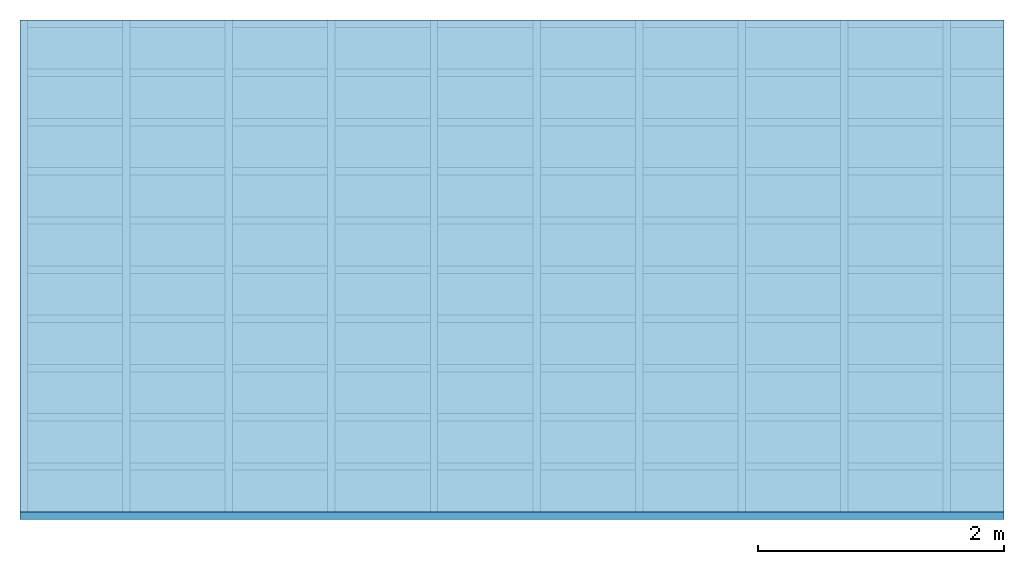
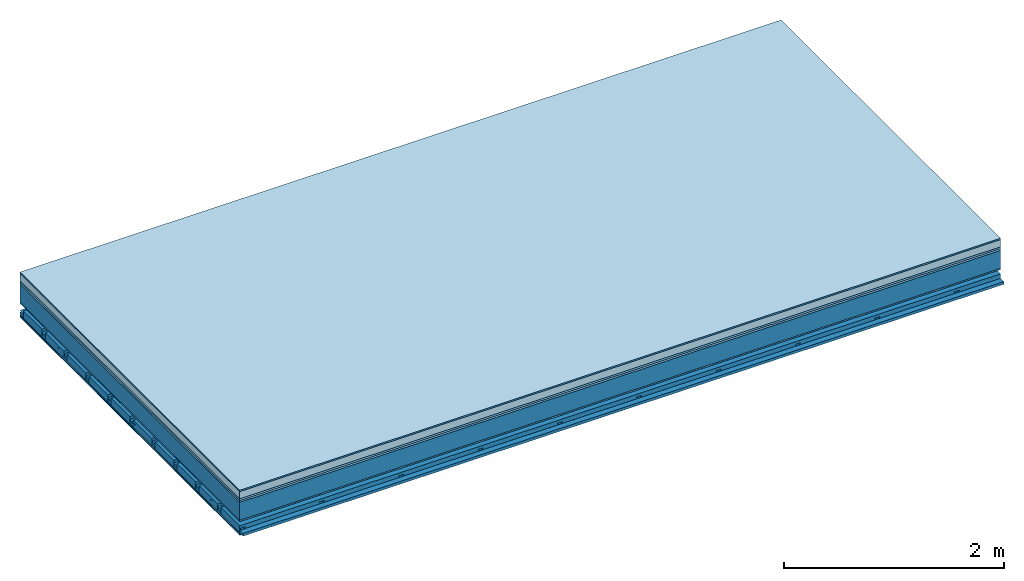
# One storey: 8 plates, 4 members, 1 element without a shape of its own.
"""IFC4 building model written with IfcOpenShell, lengths in metres."""

from ifc_helpers import new_model, si_unit, derived_unit, direction, frame, frame_2d, origin, origin_with_axes, place, context, project, spatial, polyline, rectangle, outline, extrude, material, layer, layer_set, type_object, element, aggregate, save


model = new_model("IFC4")

# Units and contexts
plan_context = context("Plan", 3, precision=1e-05, world=origin(), true_north=direction((0.0, 1.0)))
model_context = context("Model", 3, precision=1e-05, world=origin(), true_north=direction((0.0, 1.0)))
ifc_project = project(units=[si_unit("LENGTHUNIT", "METRE"), derived_unit("SOUNDPRESSUREUNIT", [(si_unit("PRESSUREUNIT", "PASCAL", prefix="MICRO"), 0)]), si_unit("ENERGYUNIT", "JOULE", prefix="MEGA"), si_unit("MASSUNIT", "GRAM", prefix="KILO"), derived_unit("THERMALTRANSMITTANCEUNIT", [(si_unit("POWERUNIT", "WATT"), 1), (si_unit("AREAUNIT", "SQUARE_METRE"), -1), (si_unit("THERMODYNAMICTEMPERATUREUNIT", "KELVIN"), -1)]), derived_unit("AREADENSITYUNIT", [(si_unit("MASSUNIT", "GRAM", prefix="KILO"), 1), (si_unit("AREAUNIT", "SQUARE_METRE"), -1)]), derived_unit("USERDEFINED", [(si_unit("ENERGYUNIT", "JOULE", prefix="MEGA"), 1), (si_unit("AREAUNIT", "SQUARE_METRE"), -1)])], contexts=[plan_context, model_context])

# Site, building, storey
site = spatial("IfcSite", under=ifc_project)
building_placement = place(None, origin())
building = spatial("IfcBuilding", under=site, at=building_placement)
storey_placement = place(building_placement, origin())
storey = spatial("IfcBuildingStorey", under=building, at=storey_placement)

# Slab, members, plates
ifc_material_1 = material(Category="11.013")
ifc_layer_1 = layer(ifc_material_1, 0.015, Name="Flooring")
ifc_material_2 = material(Name="Cement screed", Category="04.006")
ifc_layer_2 = layer(ifc_material_2, 0.08, Name="On-material")
ifc_material_3 = material(Name="Wood fiber generic product", Category="10.009")
ifc_layer_3 = layer(ifc_material_3, 0.02, Name="Impact sound insulation")
ifc_material_4 = material(Category="10.004")
ifc_layer_4 = layer(ifc_material_4, 0.02, Name="Additional insulation")
ifc_material_5 = material(Name="no composite action")
ifc_layer_5 = layer(ifc_material_5, 0.0, Name="Bond")
ifc_layer_6 = layer(None, 0.2, Name="Supporting structure")
ifc_material_6 = material(Name="of the art")
ifc_layer_7 = layer(ifc_material_6, 0.0, Name="Bond")
ifc_material_7 = material(Category="03.007")
ifc_layer_8 = layer(ifc_material_7, 0.015, Name="Lower layer 1")
ifc_layer_9 = layer(None, 0.095, Name="Coupling")
ifc_layer_10 = layer(None, 0.03, Name="Battens / profiles")
ifc_material_8 = material(Name="Plasterboard type A", Category="03.008")
ifc_layer_11 = layer(ifc_material_8, 0.0125, Name="Ceiling covering 1st layer")
ifc_layer_12 = layer(ifc_material_8, 0.0125, Name="Ceiling covering layer 2")
ifc_material_9 = material(Category="04.001")
ifc_layer_13 = layer(ifc_material_9, 0.003, Name="Surface / treatment")
ifc_layer_set = layer_set([ifc_layer_1, ifc_layer_2, ifc_layer_3, ifc_layer_4, ifc_layer_5, ifc_layer_6, ifc_layer_7, ifc_layer_8, ifc_layer_9, ifc_layer_10, ifc_layer_11, ifc_layer_12, ifc_layer_13])
slab_type = type_object("IfcSlabType", Name="A2163", PredefinedType="NOTDEFINED", material=ifc_layer_set)
slab_placement = place(None, frame((0.0, 0.0, 0.0), z_axis=(0.0, 0.0, -1.0), x_axis=(1.0, 0.0, 0.0)))
slab = element("IfcSlab", 1, at=slab_placement, inside=storey, type_object=slab_type, material=ifc_layer_set, Name="Slab #1")
ifc_material_10 = material(Name="Solid timber panel")
member_1_placement = place(slab_placement, origin())
member_1 = element("IfcMember", 2, at=member_1_placement, material=ifc_material_10, Name="Supporting structure", context=plan_context, shape_type="SweptSolid", body=[
    extrude(rectangle(XDim=1.0, YDim=0.2, at=frame_2d((0.5, 0.1), x_axis=(1.0, 0.0))), frame((0.0, 4.0, 0.135), z_axis=(0.0, -1.0, 0.0), x_axis=(1.0, 0.0, 0.0)), (0.0, 0.0, 1.0), 4.0),
    extrude(rectangle(XDim=1.0, YDim=0.2, at=frame_2d((0.5, 0.1), x_axis=(1.0, 0.0))), frame((1.0, 4.0, 0.135), z_axis=(0.0, -1.0, 0.0), x_axis=(1.0, 0.0, 0.0)), (0.0, 0.0, 1.0), 4.0),
    extrude(rectangle(XDim=1.0, YDim=0.2, at=frame_2d((0.5, 0.1), x_axis=(1.0, 0.0))), frame((2.0, 4.0, 0.135), z_axis=(0.0, -1.0, 0.0), x_axis=(1.0, 0.0, 0.0)), (0.0, 0.0, 1.0), 4.0),
    extrude(rectangle(XDim=1.0, YDim=0.2, at=frame_2d((0.5, 0.1), x_axis=(1.0, 0.0))), frame((3.0, 4.0, 0.135), z_axis=(0.0, -1.0, 0.0), x_axis=(1.0, 0.0, 0.0)), (0.0, 0.0, 1.0), 4.0),
    extrude(rectangle(XDim=1.0, YDim=0.2, at=frame_2d((0.5, 0.1), x_axis=(1.0, 0.0))), frame((4.0, 4.0, 0.135), z_axis=(0.0, -1.0, 0.0), x_axis=(1.0, 0.0, 0.0)), (0.0, 0.0, 1.0), 4.0),
    extrude(rectangle(XDim=1.0, YDim=0.2, at=frame_2d((0.5, 0.1), x_axis=(1.0, 0.0))), frame((5.0, 4.0, 0.135), z_axis=(0.0, -1.0, 0.0), x_axis=(1.0, 0.0, 0.0)), (0.0, 0.0, 1.0), 4.0),
    extrude(rectangle(XDim=1.0, YDim=0.2, at=frame_2d((0.5, 0.1), x_axis=(1.0, 0.0))), frame((6.0, 4.0, 0.135), z_axis=(0.0, -1.0, 0.0), x_axis=(1.0, 0.0, 0.0)), (0.0, 0.0, 1.0), 4.0),
    extrude(rectangle(XDim=1.0, YDim=0.2, at=frame_2d((0.5, 0.1), x_axis=(1.0, 0.0))), frame((7.0, 4.0, 0.135), z_axis=(0.0, -1.0, 0.0), x_axis=(1.0, 0.0, 0.0)), (0.0, 0.0, 1.0), 4.0),
])
ifc_material_11 = material()
member_2_placement = place(slab_placement, origin())
member_2 = element("IfcMember", 3, at=member_2_placement, material=ifc_material_11, Name="Coupling", context=plan_context, shape_type="SweptSolid", body=[
    extrude(outline(polyline([(0.0, 0.0), (0.06, 0.0), (0.04, 0.02), (0.02, 0.02), (0.0, 0.0)])), frame((0.0, 4.0, 0.425), z_axis=(0.0, -1.0, 0.0), x_axis=(1.0, 0.0, 0.0)), (0.0, 0.0, 1.0), 4.0),
    extrude(outline(polyline([(0.0, 0.0), (0.06, 0.0), (0.04, 0.02), (0.02, 0.02), (0.0, 0.0)])), frame((0.834, 4.0, 0.425), z_axis=(0.0, -1.0, 0.0), x_axis=(1.0, 0.0, 0.0)), (0.0, 0.0, 1.0), 4.0),
    extrude(outline(polyline([(0.0, 0.0), (0.06, 0.0), (0.04, 0.02), (0.02, 0.02), (0.0, 0.0)])), frame((1.668, 4.0, 0.425), z_axis=(0.0, -1.0, 0.0), x_axis=(1.0, 0.0, 0.0)), (0.0, 0.0, 1.0), 4.0),
    extrude(outline(polyline([(0.0, 0.0), (0.06, 0.0), (0.04, 0.02), (0.02, 0.02), (0.0, 0.0)])), frame((2.502, 4.0, 0.425), z_axis=(0.0, -1.0, 0.0), x_axis=(1.0, 0.0, 0.0)), (0.0, 0.0, 1.0), 4.0),
    extrude(outline(polyline([(0.0, 0.0), (0.06, 0.0), (0.04, 0.02), (0.02, 0.02), (0.0, 0.0)])), frame((3.336, 4.0, 0.425), z_axis=(0.0, -1.0, 0.0), x_axis=(1.0, 0.0, 0.0)), (0.0, 0.0, 1.0), 4.0),
    extrude(outline(polyline([(0.0, 0.0), (0.06, 0.0), (0.04, 0.02), (0.02, 0.02), (0.0, 0.0)])), frame((4.17, 4.0, 0.425), z_axis=(0.0, -1.0, 0.0), x_axis=(1.0, 0.0, 0.0)), (0.0, 0.0, 1.0), 4.0),
    extrude(outline(polyline([(0.0, 0.0), (0.06, 0.0), (0.04, 0.02), (0.02, 0.02), (0.0, 0.0)])), frame((5.004, 4.0, 0.425), z_axis=(0.0, -1.0, 0.0), x_axis=(1.0, 0.0, 0.0)), (0.0, 0.0, 1.0), 4.0),
    extrude(outline(polyline([(0.0, 0.0), (0.06, 0.0), (0.04, 0.02), (0.02, 0.02), (0.0, 0.0)])), frame((5.838, 4.0, 0.425), z_axis=(0.0, -1.0, 0.0), x_axis=(1.0, 0.0, 0.0)), (0.0, 0.0, 1.0), 4.0),
    extrude(outline(polyline([(0.0, 0.0), (0.06, 0.0), (0.04, 0.02), (0.02, 0.02), (0.0, 0.0)])), frame((6.672, 4.0, 0.425), z_axis=(0.0, -1.0, 0.0), x_axis=(1.0, 0.0, 0.0)), (0.0, 0.0, 1.0), 4.0),
    extrude(outline(polyline([(0.0, 0.0), (0.06, 0.0), (0.04, 0.02), (0.02, 0.02), (0.0, 0.0)])), frame((7.506, 4.0, 0.425), z_axis=(0.0, -1.0, 0.0), x_axis=(1.0, 0.0, 0.0)), (0.0, 0.0, 1.0), 4.0),
])
member_3_placement = place(slab_placement, origin())
member_3 = element("IfcMember", 4, at=member_3_placement, material=ifc_material_11, Name="Battens / profiles", context=plan_context, shape_type="SweptSolid", body=[
    extrude(rectangle(XDim=0.06, YDim=0.03, at=frame_2d((0.03, 0.015), x_axis=(1.0, 0.0))), frame((0.0, 0.0, 0.445), z_axis=(1.0, 0.0, 0.0), x_axis=(0.0, 1.0, 0.0)), (0.0, 0.0, 1.0), 8.0),
    extrude(rectangle(XDim=0.06, YDim=0.03, at=frame_2d((0.03, 0.015), x_axis=(1.0, 0.0))), frame((0.0, 0.4, 0.445), z_axis=(1.0, 0.0, 0.0), x_axis=(0.0, 1.0, 0.0)), (0.0, 0.0, 1.0), 8.0),
    extrude(rectangle(XDim=0.06, YDim=0.03, at=frame_2d((0.03, 0.015), x_axis=(1.0, 0.0))), frame((0.0, 0.8, 0.445), z_axis=(1.0, 0.0, 0.0), x_axis=(0.0, 1.0, 0.0)), (0.0, 0.0, 1.0), 8.0),
    extrude(rectangle(XDim=0.06, YDim=0.03, at=frame_2d((0.03, 0.015), x_axis=(1.0, 0.0))), frame((0.0, 1.2, 0.445), z_axis=(1.0, 0.0, 0.0), x_axis=(0.0, 1.0, 0.0)), (0.0, 0.0, 1.0), 8.0),
    extrude(rectangle(XDim=0.06, YDim=0.03, at=frame_2d((0.03, 0.015), x_axis=(1.0, 0.0))), frame((0.0, 1.6, 0.445), z_axis=(1.0, 0.0, 0.0), x_axis=(0.0, 1.0, 0.0)), (0.0, 0.0, 1.0), 8.0),
    extrude(rectangle(XDim=0.06, YDim=0.03, at=frame_2d((0.03, 0.015), x_axis=(1.0, 0.0))), frame((0.0, 2.0, 0.445), z_axis=(1.0, 0.0, 0.0), x_axis=(0.0, 1.0, 0.0)), (0.0, 0.0, 1.0), 8.0),
    extrude(rectangle(XDim=0.06, YDim=0.03, at=frame_2d((0.03, 0.015), x_axis=(1.0, 0.0))), frame((0.0, 2.4, 0.445), z_axis=(1.0, 0.0, 0.0), x_axis=(0.0, 1.0, 0.0)), (0.0, 0.0, 1.0), 8.0),
    extrude(rectangle(XDim=0.06, YDim=0.03, at=frame_2d((0.03, 0.015), x_axis=(1.0, 0.0))), frame((0.0, 2.8, 0.445), z_axis=(1.0, 0.0, 0.0), x_axis=(0.0, 1.0, 0.0)), (0.0, 0.0, 1.0), 8.0),
    extrude(rectangle(XDim=0.06, YDim=0.03, at=frame_2d((0.03, 0.015), x_axis=(1.0, 0.0))), frame((0.0, 3.2, 0.445), z_axis=(1.0, 0.0, 0.0), x_axis=(0.0, 1.0, 0.0)), (0.0, 0.0, 1.0), 8.0),
    extrude(rectangle(XDim=0.06, YDim=0.03, at=frame_2d((0.03, 0.015), x_axis=(1.0, 0.0))), frame((0.0, 3.6, 0.445), z_axis=(1.0, 0.0, 0.0), x_axis=(0.0, 1.0, 0.0)), (0.0, 0.0, 1.0), 8.0),
    extrude(rectangle(XDim=0.06, YDim=0.03, at=frame_2d((0.03, 0.015), x_axis=(1.0, 0.0))), frame((0.0, 4.0, 0.445), z_axis=(1.0, 0.0, 0.0), x_axis=(0.0, 1.0, 0.0)), (0.0, 0.0, 1.0), 8.0),
])
ifc_material_12 = material()
member_4_placement = place(slab_placement, origin())
member_4 = element("IfcMember", 5, at=member_4_placement, material=ifc_material_12, Name="Cavity", context=plan_context, shape_type="SweptSolid", body=[
    extrude(rectangle(XDim=0.34, YDim=0.08, at=frame_2d((0.17, 0.04), x_axis=(1.0, 0.0))), frame((0.0, 0.06, 0.395), z_axis=(1.0, 0.0, 0.0), x_axis=(0.0, 1.0, 0.0)), (0.0, 0.0, 1.0), 8.0),
    extrude(rectangle(XDim=0.34, YDim=0.08, at=frame_2d((0.17, 0.04), x_axis=(1.0, 0.0))), frame((0.0, 0.46, 0.395), z_axis=(1.0, 0.0, 0.0), x_axis=(0.0, 1.0, 0.0)), (0.0, 0.0, 1.0), 8.0),
    extrude(rectangle(XDim=0.34, YDim=0.08, at=frame_2d((0.17, 0.04), x_axis=(1.0, 0.0))), frame((0.0, 0.86, 0.395), z_axis=(1.0, 0.0, 0.0), x_axis=(0.0, 1.0, 0.0)), (0.0, 0.0, 1.0), 8.0),
    extrude(rectangle(XDim=0.34, YDim=0.08, at=frame_2d((0.17, 0.04), x_axis=(1.0, 0.0))), frame((0.0, 1.26, 0.395), z_axis=(1.0, 0.0, 0.0), x_axis=(0.0, 1.0, 0.0)), (0.0, 0.0, 1.0), 8.0),
    extrude(rectangle(XDim=0.34, YDim=0.08, at=frame_2d((0.17, 0.04), x_axis=(1.0, 0.0))), frame((0.0, 1.66, 0.395), z_axis=(1.0, 0.0, 0.0), x_axis=(0.0, 1.0, 0.0)), (0.0, 0.0, 1.0), 8.0),
    extrude(rectangle(XDim=0.34, YDim=0.08, at=frame_2d((0.17, 0.04), x_axis=(1.0, 0.0))), frame((0.0, 2.06, 0.395), z_axis=(1.0, 0.0, 0.0), x_axis=(0.0, 1.0, 0.0)), (0.0, 0.0, 1.0), 8.0),
    extrude(rectangle(XDim=0.34, YDim=0.08, at=frame_2d((0.17, 0.04), x_axis=(1.0, 0.0))), frame((0.0, 2.46, 0.395), z_axis=(1.0, 0.0, 0.0), x_axis=(0.0, 1.0, 0.0)), (0.0, 0.0, 1.0), 8.0),
    extrude(rectangle(XDim=0.34, YDim=0.08, at=frame_2d((0.17, 0.04), x_axis=(1.0, 0.0))), frame((0.0, 2.86, 0.395), z_axis=(1.0, 0.0, 0.0), x_axis=(0.0, 1.0, 0.0)), (0.0, 0.0, 1.0), 8.0),
    extrude(rectangle(XDim=0.34, YDim=0.08, at=frame_2d((0.17, 0.04), x_axis=(1.0, 0.0))), frame((0.0, 3.26, 0.395), z_axis=(1.0, 0.0, 0.0), x_axis=(0.0, 1.0, 0.0)), (0.0, 0.0, 1.0), 8.0),
    extrude(rectangle(XDim=0.34, YDim=0.08, at=frame_2d((0.17, 0.04), x_axis=(1.0, 0.0))), frame((0.0, 3.66, 0.395), z_axis=(1.0, 0.0, 0.0), x_axis=(0.0, 1.0, 0.0)), (0.0, 0.0, 1.0), 8.0),
])
plate_1_placement = place(slab_placement, origin())
plate_1 = element("IfcPlate", 6, at=plate_1_placement, material=ifc_material_1, Name="Flooring", context=plan_context, shape_type="SweptSolid", body=[
    extrude(rectangle(XDim=8.0, YDim=4.0, at=frame_2d((4.0, 2.0), x_axis=(1.0, 0.0))), origin_with_axes(), (0.0, 0.0, 1.0), 0.015),
])
plate_2_placement = place(slab_placement, origin())
plate_2 = element("IfcPlate", 7, at=plate_2_placement, material=ifc_material_2, Name="On-material", context=plan_context, shape_type="SweptSolid", body=[
    extrude(rectangle(XDim=8.0, YDim=4.0, at=frame_2d((4.0, 2.0), x_axis=(1.0, 0.0))), frame((0.0, 0.0, 0.015), z_axis=(0.0, 0.0, 1.0), x_axis=(1.0, 0.0, 0.0)), (0.0, 0.0, 1.0), 0.08),
])
plate_3_placement = place(slab_placement, origin())
plate_3 = element("IfcPlate", 8, at=plate_3_placement, material=ifc_material_3, Name="Impact sound insulation", context=plan_context, shape_type="SweptSolid", body=[
    extrude(rectangle(XDim=8.0, YDim=4.0, at=frame_2d((4.0, 2.0), x_axis=(1.0, 0.0))), frame((0.0, 0.0, 0.095), z_axis=(0.0, 0.0, 1.0), x_axis=(1.0, 0.0, 0.0)), (0.0, 0.0, 1.0), 0.02),
])
plate_4_placement = place(slab_placement, origin())
plate_4 = element("IfcPlate", 9, at=plate_4_placement, material=ifc_material_4, Name="Additional insulation", context=plan_context, shape_type="SweptSolid", body=[
    extrude(rectangle(XDim=8.0, YDim=4.0, at=frame_2d((4.0, 2.0), x_axis=(1.0, 0.0))), frame((0.0, 0.0, 0.115), z_axis=(0.0, 0.0, 1.0), x_axis=(1.0, 0.0, 0.0)), (0.0, 0.0, 1.0), 0.02),
])
plate_5_placement = place(slab_placement, origin())
plate_5 = element("IfcPlate", 10, at=plate_5_placement, material=ifc_material_7, Name="Lower layer 1", context=plan_context, shape_type="SweptSolid", body=[
    extrude(rectangle(XDim=8.0, YDim=4.0, at=frame_2d((4.0, 2.0), x_axis=(1.0, 0.0))), frame((0.0, 0.0, 0.335), z_axis=(0.0, 0.0, 1.0), x_axis=(1.0, 0.0, 0.0)), (0.0, 0.0, 1.0), 0.015),
])
plate_6_placement = place(slab_placement, origin())
plate_6 = element("IfcPlate", 11, at=plate_6_placement, material=ifc_material_8, Name="Ceiling covering 1st layer", context=plan_context, shape_type="SweptSolid", body=[
    extrude(rectangle(XDim=8.0, YDim=4.0, at=frame_2d((4.0, 2.0), x_axis=(1.0, 0.0))), frame((0.0, 0.0, 0.475), z_axis=(0.0, 0.0, 1.0), x_axis=(1.0, 0.0, 0.0)), (0.0, 0.0, 1.0), 0.0125),
])
plate_7_placement = place(slab_placement, origin())
plate_7 = element("IfcPlate", 12, at=plate_7_placement, material=ifc_material_8, Name="Ceiling covering layer 2", context=plan_context, shape_type="SweptSolid", body=[
    extrude(rectangle(XDim=8.0, YDim=4.0, at=frame_2d((4.0, 2.0), x_axis=(1.0, 0.0))), frame((0.0, 0.0, 0.4875), z_axis=(0.0, 0.0, 1.0), x_axis=(1.0, 0.0, 0.0)), (0.0, 0.0, 1.0), 0.0125),
])
plate_8_placement = place(slab_placement, origin())
plate_8 = element("IfcPlate", 13, at=plate_8_placement, material=ifc_material_9, Name="Surface / treatment", context=plan_context, shape_type="SweptSolid", body=[
    extrude(rectangle(XDim=8.0, YDim=4.0, at=frame_2d((4.0, 2.0), x_axis=(1.0, 0.0))), frame((0.0, 0.0, 0.5), z_axis=(0.0, 0.0, 1.0), x_axis=(1.0, 0.0, 0.0)), (0.0, 0.0, 1.0), 0.003),
])
aggregate(slab, [plate_1, plate_2, plate_3, plate_4, member_1, plate_5, member_2, member_3, member_4, plate_6, plate_7, plate_8])

save(model, "model.ifc")
